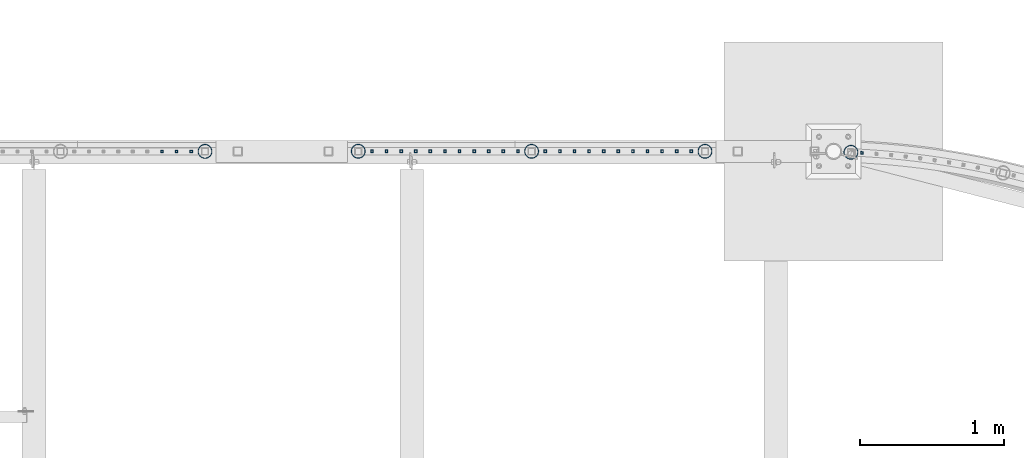
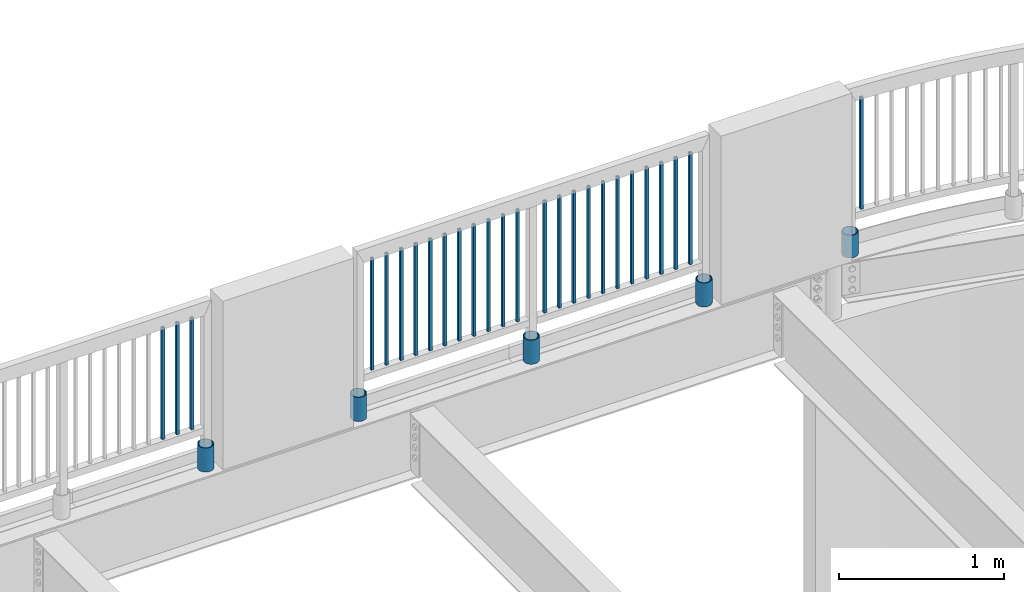
# One storey, part 248 of 975: 31 columns.
"""IFC2X3 building model written with IfcOpenShell, lengths in millimetres."""

from ifc_helpers import new_model, si_unit, frame, origin_with_axes, place, context, subcontext, project, spatial, faceted_brep, material, type_object, element, save


model = new_model("IFC2X3")

# Units and contexts
model_context = context("Model", 3, precision=1e-05, world=origin_with_axes())
body_context = subcontext(model_context, "Body", "Model", "MODEL_VIEW")
ifc_project = project(units=[si_unit("LENGTHUNIT", "METRE", prefix="MILLI"), si_unit("AREAUNIT", "SQUARE_METRE"), si_unit("VOLUMEUNIT", "CUBIC_METRE"), si_unit("MASSUNIT", "GRAM", prefix="KILO"), si_unit("TIMEUNIT", "SECOND"), si_unit("PLANEANGLEUNIT", "RADIAN"), si_unit("SOLIDANGLEUNIT", "STERADIAN"), si_unit("THERMODYNAMICTEMPERATUREUNIT", "DEGREE_CELSIUS"), si_unit("LUMINOUSINTENSITYUNIT", "LUMEN")], contexts=[model_context])

# Site, building, storey
site_placement = place(None, origin_with_axes())
site = spatial("IfcSite", under=ifc_project, at=site_placement, CompositionType="ELEMENT")
building_placement = place(site_placement, origin_with_axes())
building = spatial("IfcBuilding", under=site, at=building_placement, Name="Undefined", CompositionType="ELEMENT")
storey_placement = place(building_placement, origin_with_axes())
storey = spatial("IfcBuildingStorey", under=building, at=storey_placement, Name="Undefined", CompositionType="ELEMENT", Elevation=0.0)

# Columns
ifc_material_1 = material()
column_type_1 = type_object("IfcColumnType", Name="HSS3/4X3/4X.120_TUBES", PredefinedType="NOTDEFINED")
for number, where, z_axis, x_axis, name in (
    (1, (16621.6547998529, 29951.9537964961, 4254.50002056753), (0.0635804200166094, 0.997976718260758, -1.40352549351519e-08), (0.0, 0.0, 1.0), "PICKET"),
    (2, (15433.6768748188, 29962.8202319393, 4254.49988315824), (1.0, 0.0, 0.0), (0.0, 0.0, 1.0), "PICKET"),
    (3, (15332.0768748188, 29962.8202319393, 4254.49988315824), (1.0, 0.0, 0.0), (0.0, 0.0, 1.0), "PICKET"),
    (4, (15230.4768748188, 29962.8202319393, 4254.49988315824), (1.0, 0.0, 0.0), (0.0, 0.0, 1.0), "PICKET"),
    (5, (15128.8768748188, 29962.8202319393, 4254.49988315824), (1.0, 0.0, 0.0), (0.0, 0.0, 1.0), "PICKET"),
    (6, (15027.2768748188, 29962.8202319393, 4254.49988315824), (1.0, 0.0, 0.0), (0.0, 0.0, 1.0), "PICKET"),
    (7, (14925.6768748188, 29962.8202319393, 4254.49988315824), (1.0, 0.0, 0.0), (0.0, 0.0, 1.0), "PICKET"),
    (8, (14824.0768748188, 29962.8202319393, 4254.49988315824), (1.0, 0.0, 0.0), (0.0, 0.0, 1.0), "PICKET"),
    (9, (14722.4768748188, 29962.8202319393, 4254.49988315824), (1.0, 0.0, 0.0), (0.0, 0.0, 1.0), "PICKET"),
    (10, (14620.8768748188, 29962.8202319393, 4254.49988315824), (1.0, 0.0, 0.0), (0.0, 0.0, 1.0), "PICKET"),
    (11, (14519.2768748188, 29962.8202319393, 4254.49988315824), (1.0, 0.0, 0.0), (0.0, 0.0, 1.0), "PICKET"),
    (12, (14417.6768748188, 29962.8202319393, 4254.49988315824), (1.0, 0.0, 0.0), (0.0, 0.0, 1.0), "PICKET"),
    (13, (14227.1720010224, 29962.8296289736, 4254.49995107321), (1.0, 0.0, 0.0), (0.0, 0.0, 1.0), "PICKET"),
    (14, (14125.5720010224, 29962.8296289736, 4254.49995107321), (1.0, 0.0, 0.0), (0.0, 0.0, 1.0), "PICKET"),
    (15, (14023.9720010224, 29962.8296289736, 4254.49995107321), (1.0, 0.0, 0.0), (0.0, 0.0, 1.0), "PICKET"),
    (16, (13922.3720010224, 29962.8296289736, 4254.49995107321), (1.0, 0.0, 0.0), (0.0, 0.0, 1.0), "PICKET"),
    (17, (13820.7720010224, 29962.8296289736, 4254.49995107321), (1.0, 0.0, 0.0), (0.0, 0.0, 1.0), "PICKET"),
    (18, (13719.1720010224, 29962.8296289736, 4254.49995107321), (1.0, 0.0, 0.0), (0.0, 0.0, 1.0), "PICKET"),
    (19, (13617.5720010224, 29962.8296289736, 4254.49995107321), (1.0, 0.0, 0.0), (0.0, 0.0, 1.0), "PICKET"),
    (20, (13515.9720010224, 29962.8296289736, 4254.49995107321), (1.0, 0.0, 0.0), (0.0, 0.0, 1.0), "PICKET"),
    (21, (13414.3720010224, 29962.8296289736, 4254.49995107321), (1.0, 0.0, 0.0), (0.0, 0.0, 1.0), "PICKET"),
    (22, (13312.7720010224, 29962.8296289736, 4254.49995107321), (1.0, 0.0, 0.0), (0.0, 0.0, 1.0), "PICKET"),
    (23, (13211.1720010224, 29962.8296289736, 4254.49995107321), (1.0, 0.0, 0.0), (0.0, 0.0, 1.0), "PICKET"),
    (24, (11952.6074787112, 29962.1756613159, 4254.49117560355), (1.0, 0.0, 0.0), (0.0, 0.0, 1.0), "PICKET"),
    (25, (11851.0074787112, 29962.1756613159, 4254.49117560355), (1.0, 0.0, 0.0), (0.0, 0.0, 1.0), "PICKET"),
    (26, (11749.4074787112, 29962.1756613159, 4254.49117560355), (1.0, 0.0, 0.0), (0.0, 0.0, 1.0), "PICKET"),
):
    element("IfcColumn", number, at=place(storey_placement, frame(where, z_axis=z_axis, x_axis=x_axis)), inside=storey, type_object=column_type_1, material=ifc_material_1, Name=name, ObjectType="HSS3/4X3/4X.120_TUBES", context=body_context, shape_type="Brep", body=[
        faceted_brep([(0.0, 6.34999999998763, -6.34999999998763), (0.0, -6.35000000000582, -6.34999999998763), (825.49997943247, -6.35000000000582, -6.34999999998763), (825.49997943247, 6.34999999998763, -6.34999999998763), (0.0, -6.34999999998763, 6.34999999998763), (825.49997943247, -6.34999999998763, 6.34999999998763), (0.0, 6.35000000000946, 6.34999999998763), (825.49997943247, 6.35000000000946, 6.34999999998763), (0.0, 9.52499999997963, -9.52499999997963), (0.0, 9.52500000000873, 9.5249999999869), (825.49997943247, 9.52500000000873, 9.5249999999869), (825.49997943247, 9.52499999997963, -9.52499999997963), (0.0, -9.52499999997963, 9.52499999998327), (825.49997943247, -9.52499999997963, 9.52499999998327), (0.0, -9.52500000000873, -9.5249999999869), (825.49997943247, -9.52500000000873, -9.5249999999869)], [[[0, 1, 2, 3]], [[1, 4, 5, 2]], [[4, 6, 7, 5]], [[6, 0, 3, 7]], [[8, 9, 10, 11]], [[9, 12, 13, 10]], [[12, 14, 15, 13]], [[14, 8, 11, 15]], [[13, 15, 11, 10], [5, 7, 3, 2]], [[14, 12, 9, 8], [6, 4, 1, 0]]]),
    ])
ifc_material_2 = material(Name="STEEL/A53")
column_type_2 = type_object("IfcColumnType", Name="PIPE3-1/2STD", PredefinedType="NOTDEFINED")
column_1_placement = place(storey_placement, frame((16544.8695670041, 29955.9786823363, 3946.525), z_axis=(-0.707106781186601, 0.707106781186494, 2.36468622460961e-14), x_axis=(0.0, 0.0, 1.0)))
element("IfcColumn", 27, at=column_1_placement, inside=storey, type_object=column_type_2, material=ifc_material_2, ObjectType="PIPE3-1/2STD", context=body_context, shape_type="Brep", body=[
    faceted_brep([(0.0, -45.0595999999932, 1.45519152283669e-11), (0.0, -42.8542262016344, 13.924182159768), (168.275, -42.8542262015544, 13.9241821597034), (168.275, -45.0595999998914, 2.72848410531878e-12), (0.0, -36.45398215971, 26.4853683542424), (168.275, -36.4539821596554, 26.485368354136), (0.0, -26.4853683541623, 36.45398215979), (168.275, -26.4853683541369, 36.4539821596509), (0.0, -13.9241821596988, 42.8542262017108), (168.275, -13.9241821597025, 42.8542262015517), (0.0, 3.63797880709171e-11, 45.0596000000514), (168.275, 0.0, 45.0595999998905), (0.0, 13.9241821597716, 42.8542262017036), (168.275, 13.9241821597025, 42.8542262015517), (0.0, 26.4853683542242, 36.4539821597718), (168.275, 26.4853683541296, 36.4539821596509), (0.0, 36.4539821597537, 26.4853683542206), (168.275, 36.4539821596481, 26.4853683541342), (0.0, 42.8542262016563, 13.9241821597425), (168.275, 42.8542262015471, 13.9241821597034), (0.0, 45.0595999999932, -1.09139364212751e-11), (168.275, 45.0595999998914, -9.09494701772928e-13), (0.0, 42.8542262016344, -13.9241821597643), (168.275, 42.8542262015471, -13.9241821596997), (0.0, 36.45398215971, -26.4853683542387), (168.275, 36.4539821596481, -26.4853683541323), (0.0, 26.4853683541623, -36.4539821597864), (168.275, 26.4853683541296, -36.4539821596472), (0.0, 13.9241821596988, -42.8542262017072), (168.275, 13.9241821596952, -42.854226201548), (0.0, -3.63797880709171e-11, -45.0596000000478), (168.275, 0.0, -45.0595999998886), (0.0, -13.9241821597716, -42.8542262016963), (168.275, -13.9241821597025, -42.8542262015499), (0.0, -26.4853683542242, -36.4539821597682), (168.275, -26.4853683541369, -36.4539821596472), (0.0, -36.4539821597537, -26.4853683542169), (168.275, -36.4539821596554, -26.4853683541305), (0.0, -42.8542262016563, -13.9241821597352), (168.275, -42.8542262015544, -13.9241821597016), (0.0, -50.799999999992, 1.81898940354586e-11), (0.0, -48.3136710278013, -15.6980633142484), (168.275, -48.3136710276813, -15.6980633142075), (168.275, -50.7999999998792, 9.09494701772928e-13), (0.0, -41.0980633142644, -29.8594908164741), (168.275, -41.0980633141517, -29.8594908163841), (0.0, -29.859490816485, -41.0980633142826), (168.275, -29.8594908163868, -41.0980633141471), (0.0, -15.6980633142848, -48.313671027845), (168.275, -15.6980633142084, -48.3136710276767), (0.0, -4.36557456851006e-11, -50.8000000000575), (168.275, 0.0, -50.7999999998747), (0.0, 15.6980633142011, -48.3136710278523), (168.275, 15.6980633142084, -48.3136710276749), (0.0, 29.8594908164159, -41.0980633143045), (168.275, 29.8594908163868, -41.0980633141471), (0.0, 41.0980633142135, -29.8594908165032), (168.275, 41.0980633141444, -29.8594908163859), (0.0, 48.3136710277722, -15.6980633142775), (168.275, 48.313671027674, -15.6980633142057), (0.0, 50.799999999992, -1.45519152283669e-11), (168.275, 50.7999999998719, 9.09494701772928e-13), (0.0, 48.313671027794, 15.6980633142521), (168.275, 48.313671027674, 15.6980633142093), (0.0, 41.0980633142644, 29.8594908164814), (168.275, 41.0980633141444, 29.8594908163877), (0.0, 29.859490816485, 41.0980633142863), (168.275, 29.8594908163795, 41.0980633141507), (0.0, 15.6980633142848, 48.3136710278486), (168.275, 15.6980633142084, 48.3136710276785), (0.0, 4.00177668780088e-11, 50.8000000000611), (168.275, 0.0, 50.7999999998765), (0.0, -15.6980633142011, 48.3136710278559), (168.275, -15.6980633142084, 48.3136710276785), (0.0, -29.8594908164159, 41.0980633143081), (168.275, -29.8594908163941, 41.0980633141507), (0.0, -41.0980633142171, 29.8594908165069), (168.275, -41.0980633141517, 29.8594908163896), (0.0, -48.3136710277722, 15.6980633142812), (168.275, -48.3136710276813, 15.6980633142093)], [[[0, 1, 2, 3]], [[1, 4, 5, 2]], [[4, 6, 7, 5]], [[6, 8, 9, 7]], [[8, 10, 11, 9]], [[10, 12, 13, 11]], [[12, 14, 15, 13]], [[14, 16, 17, 15]], [[16, 18, 19, 17]], [[18, 20, 21, 19]], [[20, 22, 23, 21]], [[22, 24, 25, 23]], [[24, 26, 27, 25]], [[26, 28, 29, 27]], [[28, 30, 31, 29]], [[30, 32, 33, 31]], [[32, 34, 35, 33]], [[34, 36, 37, 35]], [[36, 38, 39, 37]], [[38, 0, 3, 39]], [[40, 41, 42, 43]], [[41, 44, 45, 42]], [[44, 46, 47, 45]], [[46, 48, 49, 47]], [[48, 50, 51, 49]], [[50, 52, 53, 51]], [[52, 54, 55, 53]], [[54, 56, 57, 55]], [[56, 58, 59, 57]], [[58, 60, 61, 59]], [[60, 62, 63, 61]], [[62, 64, 65, 63]], [[64, 66, 67, 65]], [[66, 68, 69, 67]], [[68, 70, 71, 69]], [[70, 72, 73, 71]], [[72, 74, 75, 73]], [[74, 76, 77, 75]], [[76, 78, 79, 77]], [[78, 40, 43, 79]], [[45, 47, 49, 51, 53, 55, 57, 59, 61, 63, 65, 67, 69, 71, 73, 75, 77, 79, 43, 42], [5, 7, 9, 11, 13, 15, 17, 19, 21, 23, 25, 27, 29, 31, 33, 35, 37, 39, 3, 2]], [[78, 76, 74, 72, 70, 68, 66, 64, 62, 60, 58, 56, 54, 52, 50, 48, 46, 44, 41, 40], [38, 36, 34, 32, 30, 28, 26, 24, 22, 20, 18, 16, 14, 12, 10, 8, 6, 4, 1, 0]]]),
])
column_2_placement = place(storey_placement, frame((14322.4236175546, 29962.8586567184, 3937.0), z_axis=(-0.707106781186601, 0.707106781186494, 2.36468622460961e-14), x_axis=(0.0, 0.0, 1.0)))
element("IfcColumn", 28, at=column_2_placement, inside=storey, type_object=column_type_2, material=ifc_material_2, ObjectType="PIPE3-1/2STD", context=body_context, shape_type="Brep", body=[
    faceted_brep([(0.0, -45.0595999999932, 1.45519152283669e-11), (0.0, -42.8542262016344, 13.924182159768), (177.8, -42.8542262016344, 13.924182159768), (177.8, -45.0595999999932, 1.45519152283669e-11), (0.0, -36.45398215971, 26.4853683542424), (177.8, -36.45398215971, 26.4853683542424), (0.0, -26.4853683541623, 36.45398215979), (177.8, -26.4853683541623, 36.45398215979), (0.0, -13.9241821596988, 42.8542262017108), (177.8, -13.9241821596988, 42.8542262017108), (0.0, 3.63797880709171e-11, 45.0596000000514), (177.8, 3.63797880709171e-11, 45.0596000000514), (0.0, 13.9241821597716, 42.8542262017036), (177.8, 13.9241821597716, 42.8542262017036), (0.0, 26.4853683542242, 36.4539821597718), (177.8, 26.4853683542242, 36.4539821597718), (0.0, 36.4539821597537, 26.4853683542206), (177.8, 36.4539821597537, 26.4853683542206), (0.0, 42.8542262016563, 13.9241821597425), (177.8, 42.8542262016563, 13.9241821597425), (0.0, 45.0595999999932, -1.09139364212751e-11), (177.8, 45.0595999999932, -1.09139364212751e-11), (0.0, 42.8542262016344, -13.9241821597643), (177.8, 42.8542262016344, -13.9241821597643), (0.0, 36.45398215971, -26.4853683542387), (177.8, 36.45398215971, -26.4853683542387), (0.0, 26.4853683541623, -36.4539821597864), (177.8, 26.4853683541623, -36.4539821597864), (0.0, 13.9241821596988, -42.8542262017072), (177.8, 13.9241821596988, -42.8542262017072), (0.0, -3.63797880709171e-11, -45.0596000000478), (177.8, -3.63797880709171e-11, -45.0596000000478), (0.0, -13.9241821597716, -42.8542262016963), (177.8, -13.9241821597716, -42.8542262016963), (0.0, -26.4853683542242, -36.4539821597682), (177.8, -26.4853683542242, -36.4539821597682), (0.0, -36.4539821597537, -26.4853683542169), (177.8, -36.4539821597537, -26.4853683542169), (0.0, -42.8542262016563, -13.9241821597352), (177.8, -42.8542262016563, -13.9241821597352), (0.0, -50.799999999992, 1.81898940354586e-11), (0.0, -48.3136710278013, -15.6980633142484), (177.8, -48.3136710278013, -15.6980633142484), (177.8, -50.799999999992, 1.81898940354586e-11), (0.0, -41.0980633142644, -29.8594908164741), (177.8, -41.0980633142644, -29.8594908164741), (0.0, -29.859490816485, -41.0980633142826), (177.8, -29.859490816485, -41.0980633142826), (0.0, -15.6980633142848, -48.313671027845), (177.8, -15.6980633142848, -48.313671027845), (0.0, -4.36557456851006e-11, -50.8000000000575), (177.8, -4.36557456851006e-11, -50.8000000000575), (0.0, 15.6980633142011, -48.3136710278523), (177.8, 15.6980633142011, -48.3136710278523), (0.0, 29.8594908164159, -41.0980633143045), (177.8, 29.8594908164159, -41.0980633143045), (0.0, 41.0980633142135, -29.8594908165032), (177.8, 41.0980633142135, -29.8594908165032), (0.0, 48.3136710277722, -15.6980633142775), (177.8, 48.3136710277722, -15.6980633142775), (0.0, 50.799999999992, -1.45519152283669e-11), (177.8, 50.799999999992, -1.45519152283669e-11), (0.0, 48.313671027794, 15.6980633142521), (177.8, 48.313671027794, 15.6980633142521), (0.0, 41.0980633142644, 29.8594908164814), (177.8, 41.0980633142644, 29.8594908164814), (0.0, 29.859490816485, 41.0980633142863), (177.8, 29.859490816485, 41.0980633142863), (0.0, 15.6980633142848, 48.3136710278486), (177.8, 15.6980633142848, 48.3136710278486), (0.0, 4.00177668780088e-11, 50.8000000000611), (177.8, 4.00177668780088e-11, 50.8000000000611), (0.0, -15.6980633142011, 48.3136710278559), (177.8, -15.6980633142011, 48.3136710278559), (0.0, -29.8594908164159, 41.0980633143081), (177.8, -29.8594908164159, 41.0980633143081), (0.0, -41.0980633142171, 29.8594908165069), (177.8, -41.0980633142171, 29.8594908165069), (0.0, -48.3136710277722, 15.6980633142812), (177.8, -48.3136710277722, 15.6980633142812)], [[[0, 1, 2, 3]], [[1, 4, 5, 2]], [[4, 6, 7, 5]], [[6, 8, 9, 7]], [[8, 10, 11, 9]], [[10, 12, 13, 11]], [[12, 14, 15, 13]], [[14, 16, 17, 15]], [[16, 18, 19, 17]], [[18, 20, 21, 19]], [[20, 22, 23, 21]], [[22, 24, 25, 23]], [[24, 26, 27, 25]], [[26, 28, 29, 27]], [[28, 30, 31, 29]], [[30, 32, 33, 31]], [[32, 34, 35, 33]], [[34, 36, 37, 35]], [[36, 38, 39, 37]], [[38, 0, 3, 39]], [[40, 41, 42, 43]], [[41, 44, 45, 42]], [[44, 46, 47, 45]], [[46, 48, 49, 47]], [[48, 50, 51, 49]], [[50, 52, 53, 51]], [[52, 54, 55, 53]], [[54, 56, 57, 55]], [[56, 58, 59, 57]], [[58, 60, 61, 59]], [[60, 62, 63, 61]], [[62, 64, 65, 63]], [[64, 66, 67, 65]], [[66, 68, 69, 67]], [[68, 70, 71, 69]], [[70, 72, 73, 71]], [[72, 74, 75, 73]], [[74, 76, 77, 75]], [[76, 78, 79, 77]], [[78, 40, 43, 79]], [[45, 47, 49, 51, 53, 55, 57, 59, 61, 63, 65, 67, 69, 71, 73, 75, 77, 79, 43, 42], [5, 7, 9, 11, 13, 15, 17, 19, 21, 23, 25, 27, 29, 31, 33, 35, 37, 39, 3, 2]], [[78, 76, 74, 72, 70, 68, 66, 64, 62, 60, 58, 56, 54, 52, 50, 48, 46, 44, 41, 40], [38, 36, 34, 32, 30, 28, 26, 24, 22, 20, 18, 16, 14, 12, 10, 8, 6, 4, 1, 0]]]),
])
column_3_placement = place(storey_placement, frame((12049.2666214244, 29962.32707356, 3937.0), z_axis=(-0.707106781186601, 0.707106781186494, 2.36468622460961e-14), x_axis=(0.0, 0.0, 1.0)))
element("IfcColumn", 29, at=column_3_placement, inside=storey, type_object=column_type_2, material=ifc_material_2, ObjectType="PIPE3-1/2STD", context=body_context, shape_type="Brep", body=[
    faceted_brep([(0.0, -45.0595999999932, 1.45519152283669e-11), (0.0, -42.8542262016344, 13.924182159768), (177.8, -42.8542262016344, 13.924182159768), (177.8, -45.0595999999932, 1.45519152283669e-11), (0.0, -36.45398215971, 26.4853683542424), (177.8, -36.45398215971, 26.4853683542424), (0.0, -26.4853683541623, 36.45398215979), (177.8, -26.4853683541623, 36.45398215979), (0.0, -13.9241821596988, 42.8542262017108), (177.8, -13.9241821596988, 42.8542262017108), (0.0, 3.63797880709171e-11, 45.0596000000514), (177.8, 3.63797880709171e-11, 45.0596000000514), (0.0, 13.9241821597716, 42.8542262017036), (177.8, 13.9241821597716, 42.8542262017036), (0.0, 26.4853683542242, 36.4539821597718), (177.8, 26.4853683542242, 36.4539821597718), (0.0, 36.4539821597537, 26.4853683542206), (177.8, 36.4539821597537, 26.4853683542206), (0.0, 42.8542262016563, 13.9241821597425), (177.8, 42.8542262016563, 13.9241821597425), (0.0, 45.0595999999932, -1.09139364212751e-11), (177.8, 45.0595999999932, -1.09139364212751e-11), (0.0, 42.8542262016344, -13.9241821597643), (177.8, 42.8542262016344, -13.9241821597643), (0.0, 36.45398215971, -26.4853683542387), (177.8, 36.45398215971, -26.4853683542387), (0.0, 26.4853683541623, -36.4539821597864), (177.8, 26.4853683541623, -36.4539821597864), (0.0, 13.9241821596988, -42.8542262017072), (177.8, 13.9241821596988, -42.8542262017072), (0.0, -3.63797880709171e-11, -45.0596000000478), (177.8, -3.63797880709171e-11, -45.0596000000478), (0.0, -13.9241821597716, -42.8542262016963), (177.8, -13.9241821597716, -42.8542262016963), (0.0, -26.4853683542242, -36.4539821597682), (177.8, -26.4853683542242, -36.4539821597682), (0.0, -36.4539821597537, -26.4853683542169), (177.8, -36.4539821597537, -26.4853683542169), (0.0, -42.8542262016563, -13.9241821597352), (177.8, -42.8542262016563, -13.9241821597352), (0.0, -50.799999999992, 1.81898940354586e-11), (0.0, -48.3136710278013, -15.6980633142484), (177.8, -48.3136710278013, -15.6980633142484), (177.8, -50.799999999992, 1.81898940354586e-11), (0.0, -41.0980633142644, -29.8594908164741), (177.8, -41.0980633142644, -29.8594908164741), (0.0, -29.859490816485, -41.0980633142826), (177.8, -29.859490816485, -41.0980633142826), (0.0, -15.6980633142848, -48.313671027845), (177.8, -15.6980633142848, -48.313671027845), (0.0, -4.36557456851006e-11, -50.8000000000575), (177.8, -4.36557456851006e-11, -50.8000000000575), (0.0, 15.6980633142011, -48.3136710278523), (177.8, 15.6980633142011, -48.3136710278523), (0.0, 29.8594908164159, -41.0980633143045), (177.8, 29.8594908164159, -41.0980633143045), (0.0, 41.0980633142135, -29.8594908165032), (177.8, 41.0980633142135, -29.8594908165032), (0.0, 48.3136710277722, -15.6980633142775), (177.8, 48.3136710277722, -15.6980633142775), (0.0, 50.799999999992, -1.45519152283669e-11), (177.8, 50.799999999992, -1.45519152283669e-11), (0.0, 48.313671027794, 15.6980633142521), (177.8, 48.313671027794, 15.6980633142521), (0.0, 41.0980633142644, 29.8594908164814), (177.8, 41.0980633142644, 29.8594908164814), (0.0, 29.859490816485, 41.0980633142863), (177.8, 29.859490816485, 41.0980633142863), (0.0, 15.6980633142848, 48.3136710278486), (177.8, 15.6980633142848, 48.3136710278486), (0.0, 4.00177668780088e-11, 50.8000000000611), (177.8, 4.00177668780088e-11, 50.8000000000611), (0.0, -15.6980633142011, 48.3136710278559), (177.8, -15.6980633142011, 48.3136710278559), (0.0, -29.8594908164159, 41.0980633143081), (177.8, -29.8594908164159, 41.0980633143081), (0.0, -41.0980633142171, 29.8594908165069), (177.8, -41.0980633142171, 29.8594908165069), (0.0, -48.3136710277722, 15.6980633142812), (177.8, -48.3136710277722, 15.6980633142812)], [[[0, 1, 2, 3]], [[1, 4, 5, 2]], [[4, 6, 7, 5]], [[6, 8, 9, 7]], [[8, 10, 11, 9]], [[10, 12, 13, 11]], [[12, 14, 15, 13]], [[14, 16, 17, 15]], [[16, 18, 19, 17]], [[18, 20, 21, 19]], [[20, 22, 23, 21]], [[22, 24, 25, 23]], [[24, 26, 27, 25]], [[26, 28, 29, 27]], [[28, 30, 31, 29]], [[30, 32, 33, 31]], [[32, 34, 35, 33]], [[34, 36, 37, 35]], [[36, 38, 39, 37]], [[38, 0, 3, 39]], [[40, 41, 42, 43]], [[41, 44, 45, 42]], [[44, 46, 47, 45]], [[46, 48, 49, 47]], [[48, 50, 51, 49]], [[50, 52, 53, 51]], [[52, 54, 55, 53]], [[54, 56, 57, 55]], [[56, 58, 59, 57]], [[58, 60, 61, 59]], [[60, 62, 63, 61]], [[62, 64, 65, 63]], [[64, 66, 67, 65]], [[66, 68, 69, 67]], [[68, 70, 71, 69]], [[70, 72, 73, 71]], [[72, 74, 75, 73]], [[74, 76, 77, 75]], [[76, 78, 79, 77]], [[78, 40, 43, 79]], [[45, 47, 49, 51, 53, 55, 57, 59, 61, 63, 65, 67, 69, 71, 73, 75, 77, 79, 43, 42], [5, 7, 9, 11, 13, 15, 17, 19, 21, 23, 25, 27, 29, 31, 33, 35, 37, 39, 3, 2]], [[78, 76, 74, 72, 70, 68, 66, 64, 62, 60, 58, 56, 54, 52, 50, 48, 46, 44, 41, 40], [38, 36, 34, 32, 30, 28, 26, 24, 22, 20, 18, 16, 14, 12, 10, 8, 6, 4, 1, 0]]]),
])
column_4_placement = place(storey_placement, frame((13116.058255378, 29963.1334326591, 3937.0), z_axis=(-0.707106781186601, 0.707106781186494, 2.36468622460961e-14), x_axis=(0.0, 0.0, 1.0)))
element("IfcColumn", 30, at=column_4_placement, inside=storey, type_object=column_type_2, material=ifc_material_2, ObjectType="PIPE3-1/2STD", context=body_context, shape_type="Brep", body=[
    faceted_brep([(0.0, -45.0595999999932, 1.45519152283669e-11), (0.0, -42.8542262016344, 13.924182159768), (177.8, -42.8542262016344, 13.924182159768), (177.8, -45.0595999999932, 1.45519152283669e-11), (0.0, -36.45398215971, 26.4853683542424), (177.8, -36.45398215971, 26.4853683542424), (0.0, -26.4853683541623, 36.45398215979), (177.8, -26.4853683541623, 36.45398215979), (0.0, -13.9241821596988, 42.8542262017108), (177.8, -13.9241821596988, 42.8542262017108), (0.0, 3.63797880709171e-11, 45.0596000000514), (177.8, 3.63797880709171e-11, 45.0596000000514), (0.0, 13.9241821597716, 42.8542262017036), (177.8, 13.9241821597716, 42.8542262017036), (0.0, 26.4853683542242, 36.4539821597718), (177.8, 26.4853683542242, 36.4539821597718), (0.0, 36.4539821597537, 26.4853683542206), (177.8, 36.4539821597537, 26.4853683542206), (0.0, 42.8542262016563, 13.9241821597425), (177.8, 42.8542262016563, 13.9241821597425), (0.0, 45.0595999999932, -1.09139364212751e-11), (177.8, 45.0595999999932, -1.09139364212751e-11), (0.0, 42.8542262016344, -13.9241821597643), (177.8, 42.8542262016344, -13.9241821597643), (0.0, 36.45398215971, -26.4853683542387), (177.8, 36.45398215971, -26.4853683542387), (0.0, 26.4853683541623, -36.4539821597864), (177.8, 26.4853683541623, -36.4539821597864), (0.0, 13.9241821596988, -42.8542262017072), (177.8, 13.9241821596988, -42.8542262017072), (0.0, -3.63797880709171e-11, -45.0596000000478), (177.8, -3.63797880709171e-11, -45.0596000000478), (0.0, -13.9241821597716, -42.8542262016963), (177.8, -13.9241821597716, -42.8542262016963), (0.0, -26.4853683542242, -36.4539821597682), (177.8, -26.4853683542242, -36.4539821597682), (0.0, -36.4539821597537, -26.4853683542169), (177.8, -36.4539821597537, -26.4853683542169), (0.0, -42.8542262016563, -13.9241821597352), (177.8, -42.8542262016563, -13.9241821597352), (0.0, -50.799999999992, 1.81898940354586e-11), (0.0, -48.3136710278013, -15.6980633142484), (177.8, -48.3136710278013, -15.6980633142484), (177.8, -50.799999999992, 1.81898940354586e-11), (0.0, -41.0980633142644, -29.8594908164741), (177.8, -41.0980633142644, -29.8594908164741), (0.0, -29.859490816485, -41.0980633142826), (177.8, -29.859490816485, -41.0980633142826), (0.0, -15.6980633142848, -48.313671027845), (177.8, -15.6980633142848, -48.313671027845), (0.0, -4.36557456851006e-11, -50.8000000000575), (177.8, -4.36557456851006e-11, -50.8000000000575), (0.0, 15.6980633142011, -48.3136710278523), (177.8, 15.6980633142011, -48.3136710278523), (0.0, 29.8594908164159, -41.0980633143045), (177.8, 29.8594908164159, -41.0980633143045), (0.0, 41.0980633142135, -29.8594908165032), (177.8, 41.0980633142135, -29.8594908165032), (0.0, 48.3136710277722, -15.6980633142775), (177.8, 48.3136710277722, -15.6980633142775), (0.0, 50.799999999992, -1.45519152283669e-11), (177.8, 50.799999999992, -1.45519152283669e-11), (0.0, 48.313671027794, 15.6980633142521), (177.8, 48.313671027794, 15.6980633142521), (0.0, 41.0980633142644, 29.8594908164814), (177.8, 41.0980633142644, 29.8594908164814), (0.0, 29.859490816485, 41.0980633142863), (177.8, 29.859490816485, 41.0980633142863), (0.0, 15.6980633142848, 48.3136710278486), (177.8, 15.6980633142848, 48.3136710278486), (0.0, 4.00177668780088e-11, 50.8000000000611), (177.8, 4.00177668780088e-11, 50.8000000000611), (0.0, -15.6980633142011, 48.3136710278559), (177.8, -15.6980633142011, 48.3136710278559), (0.0, -29.8594908164159, 41.0980633143081), (177.8, -29.8594908164159, 41.0980633143081), (0.0, -41.0980633142171, 29.8594908165069), (177.8, -41.0980633142171, 29.8594908165069), (0.0, -48.3136710277722, 15.6980633142812), (177.8, -48.3136710277722, 15.6980633142812)], [[[0, 1, 2, 3]], [[1, 4, 5, 2]], [[4, 6, 7, 5]], [[6, 8, 9, 7]], [[8, 10, 11, 9]], [[10, 12, 13, 11]], [[12, 14, 15, 13]], [[14, 16, 17, 15]], [[16, 18, 19, 17]], [[18, 20, 21, 19]], [[20, 22, 23, 21]], [[22, 24, 25, 23]], [[24, 26, 27, 25]], [[26, 28, 29, 27]], [[28, 30, 31, 29]], [[30, 32, 33, 31]], [[32, 34, 35, 33]], [[34, 36, 37, 35]], [[36, 38, 39, 37]], [[38, 0, 3, 39]], [[40, 41, 42, 43]], [[41, 44, 45, 42]], [[44, 46, 47, 45]], [[46, 48, 49, 47]], [[48, 50, 51, 49]], [[50, 52, 53, 51]], [[52, 54, 55, 53]], [[54, 56, 57, 55]], [[56, 58, 59, 57]], [[58, 60, 61, 59]], [[60, 62, 63, 61]], [[62, 64, 65, 63]], [[64, 66, 67, 65]], [[66, 68, 69, 67]], [[68, 70, 71, 69]], [[70, 72, 73, 71]], [[72, 74, 75, 73]], [[74, 76, 77, 75]], [[76, 78, 79, 77]], [[78, 40, 43, 79]], [[45, 47, 49, 51, 53, 55, 57, 59, 61, 63, 65, 67, 69, 71, 73, 75, 77, 79, 43, 42], [5, 7, 9, 11, 13, 15, 17, 19, 21, 23, 25, 27, 29, 31, 33, 35, 37, 39, 3, 2]], [[78, 76, 74, 72, 70, 68, 66, 64, 62, 60, 58, 56, 54, 52, 50, 48, 46, 44, 41, 40], [38, 36, 34, 32, 30, 28, 26, 24, 22, 20, 18, 16, 14, 12, 10, 8, 6, 4, 1, 0]]]),
])
column_5_placement = place(storey_placement, frame((15529.0680040041, 29963.1224323363, 3937.0), z_axis=(-0.707106781186601, 0.707106781186494, 2.36468622460961e-14), x_axis=(0.0, 0.0, 1.0)))
element("IfcColumn", 31, at=column_5_placement, inside=storey, type_object=column_type_2, material=ifc_material_2, ObjectType="PIPE3-1/2STD", context=body_context, shape_type="Brep", body=[
    faceted_brep([(0.0, -45.0595999999932, 1.45519152283669e-11), (0.0, -42.8542262016344, 13.924182159768), (177.8, -42.8542262016344, 13.924182159768), (177.8, -45.0595999999932, 1.45519152283669e-11), (0.0, -36.45398215971, 26.4853683542424), (177.8, -36.45398215971, 26.4853683542424), (0.0, -26.4853683541623, 36.45398215979), (177.8, -26.4853683541623, 36.45398215979), (0.0, -13.9241821596988, 42.8542262017108), (177.8, -13.9241821596988, 42.8542262017108), (0.0, 3.63797880709171e-11, 45.0596000000514), (177.8, 3.63797880709171e-11, 45.0596000000514), (0.0, 13.9241821597716, 42.8542262017036), (177.8, 13.9241821597716, 42.8542262017036), (0.0, 26.4853683542242, 36.4539821597718), (177.8, 26.4853683542242, 36.4539821597718), (0.0, 36.4539821597537, 26.4853683542206), (177.8, 36.4539821597537, 26.4853683542206), (0.0, 42.8542262016563, 13.9241821597425), (177.8, 42.8542262016563, 13.9241821597425), (0.0, 45.0595999999932, -1.09139364212751e-11), (177.8, 45.0595999999932, -1.09139364212751e-11), (0.0, 42.8542262016344, -13.9241821597643), (177.8, 42.8542262016344, -13.9241821597643), (0.0, 36.45398215971, -26.4853683542387), (177.8, 36.45398215971, -26.4853683542387), (0.0, 26.4853683541623, -36.4539821597864), (177.8, 26.4853683541623, -36.4539821597864), (0.0, 13.9241821596988, -42.8542262017072), (177.8, 13.9241821596988, -42.8542262017072), (0.0, -3.63797880709171e-11, -45.0596000000478), (177.8, -3.63797880709171e-11, -45.0596000000478), (0.0, -13.9241821597716, -42.8542262016963), (177.8, -13.9241821597716, -42.8542262016963), (0.0, -26.4853683542242, -36.4539821597682), (177.8, -26.4853683542242, -36.4539821597682), (0.0, -36.4539821597537, -26.4853683542169), (177.8, -36.4539821597537, -26.4853683542169), (0.0, -42.8542262016563, -13.9241821597352), (177.8, -42.8542262016563, -13.9241821597352), (0.0, -50.799999999992, 1.81898940354586e-11), (0.0, -48.3136710278013, -15.6980633142484), (177.8, -48.3136710278013, -15.6980633142484), (177.8, -50.799999999992, 1.81898940354586e-11), (0.0, -41.0980633142644, -29.8594908164741), (177.8, -41.0980633142644, -29.8594908164741), (0.0, -29.859490816485, -41.0980633142826), (177.8, -29.859490816485, -41.0980633142826), (0.0, -15.6980633142848, -48.313671027845), (177.8, -15.6980633142848, -48.313671027845), (0.0, -4.36557456851006e-11, -50.8000000000575), (177.8, -4.36557456851006e-11, -50.8000000000575), (0.0, 15.6980633142011, -48.3136710278523), (177.8, 15.6980633142011, -48.3136710278523), (0.0, 29.8594908164159, -41.0980633143045), (177.8, 29.8594908164159, -41.0980633143045), (0.0, 41.0980633142135, -29.8594908165032), (177.8, 41.0980633142135, -29.8594908165032), (0.0, 48.3136710277722, -15.6980633142775), (177.8, 48.3136710277722, -15.6980633142775), (0.0, 50.799999999992, -1.45519152283669e-11), (177.8, 50.799999999992, -1.45519152283669e-11), (0.0, 48.313671027794, 15.6980633142521), (177.8, 48.313671027794, 15.6980633142521), (0.0, 41.0980633142644, 29.8594908164814), (177.8, 41.0980633142644, 29.8594908164814), (0.0, 29.859490816485, 41.0980633142863), (177.8, 29.859490816485, 41.0980633142863), (0.0, 15.6980633142848, 48.3136710278486), (177.8, 15.6980633142848, 48.3136710278486), (0.0, 4.00177668780088e-11, 50.8000000000611), (177.8, 4.00177668780088e-11, 50.8000000000611), (0.0, -15.6980633142011, 48.3136710278559), (177.8, -15.6980633142011, 48.3136710278559), (0.0, -29.8594908164159, 41.0980633143081), (177.8, -29.8594908164159, 41.0980633143081), (0.0, -41.0980633142171, 29.8594908165069), (177.8, -41.0980633142171, 29.8594908165069), (0.0, -48.3136710277722, 15.6980633142812), (177.8, -48.3136710277722, 15.6980633142812)], [[[0, 1, 2, 3]], [[1, 4, 5, 2]], [[4, 6, 7, 5]], [[6, 8, 9, 7]], [[8, 10, 11, 9]], [[10, 12, 13, 11]], [[12, 14, 15, 13]], [[14, 16, 17, 15]], [[16, 18, 19, 17]], [[18, 20, 21, 19]], [[20, 22, 23, 21]], [[22, 24, 25, 23]], [[24, 26, 27, 25]], [[26, 28, 29, 27]], [[28, 30, 31, 29]], [[30, 32, 33, 31]], [[32, 34, 35, 33]], [[34, 36, 37, 35]], [[36, 38, 39, 37]], [[38, 0, 3, 39]], [[40, 41, 42, 43]], [[41, 44, 45, 42]], [[44, 46, 47, 45]], [[46, 48, 49, 47]], [[48, 50, 51, 49]], [[50, 52, 53, 51]], [[52, 54, 55, 53]], [[54, 56, 57, 55]], [[56, 58, 59, 57]], [[58, 60, 61, 59]], [[60, 62, 63, 61]], [[62, 64, 65, 63]], [[64, 66, 67, 65]], [[66, 68, 69, 67]], [[68, 70, 71, 69]], [[70, 72, 73, 71]], [[72, 74, 75, 73]], [[74, 76, 77, 75]], [[76, 78, 79, 77]], [[78, 40, 43, 79]], [[45, 47, 49, 51, 53, 55, 57, 59, 61, 63, 65, 67, 69, 71, 73, 75, 77, 79, 43, 42], [5, 7, 9, 11, 13, 15, 17, 19, 21, 23, 25, 27, 29, 31, 33, 35, 37, 39, 3, 2]], [[78, 76, 74, 72, 70, 68, 66, 64, 62, 60, 58, 56, 54, 52, 50, 48, 46, 44, 41, 40], [38, 36, 34, 32, 30, 28, 26, 24, 22, 20, 18, 16, 14, 12, 10, 8, 6, 4, 1, 0]]]),
])

save(model, "model.ifc")
